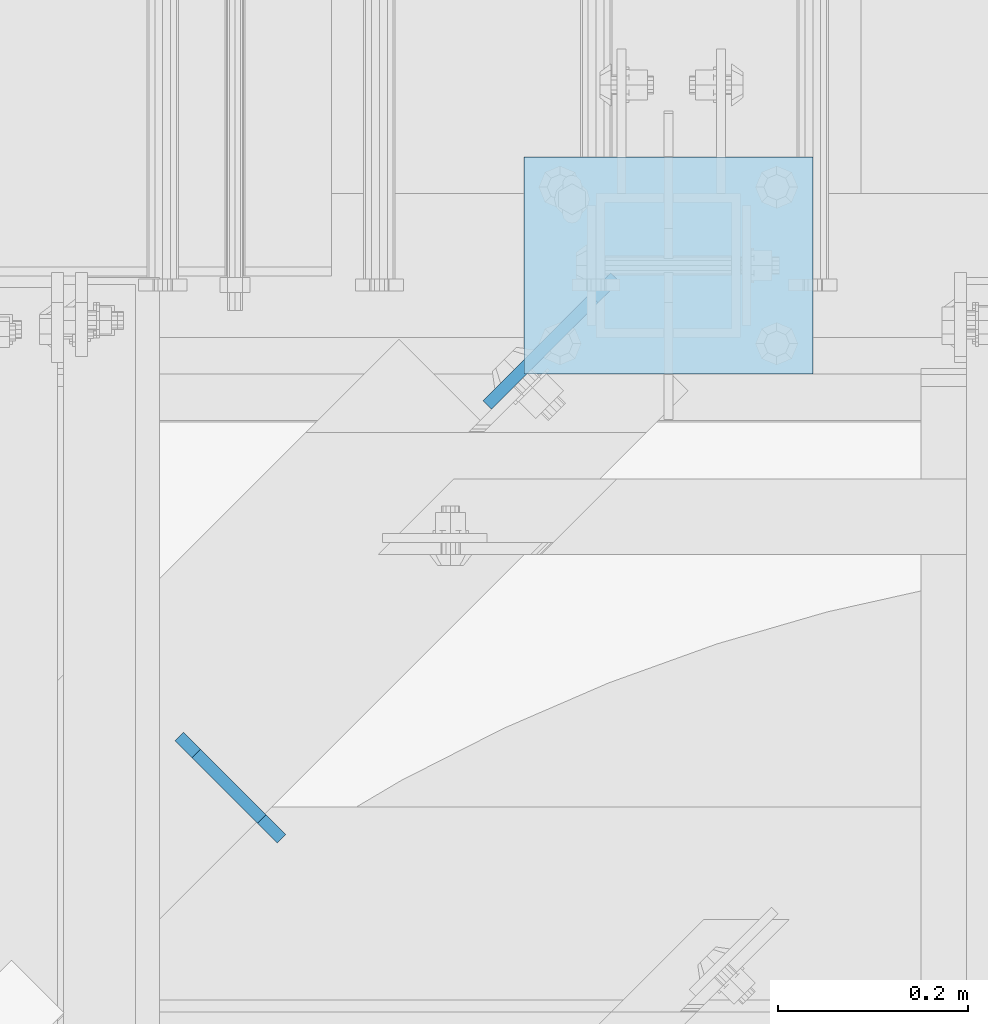
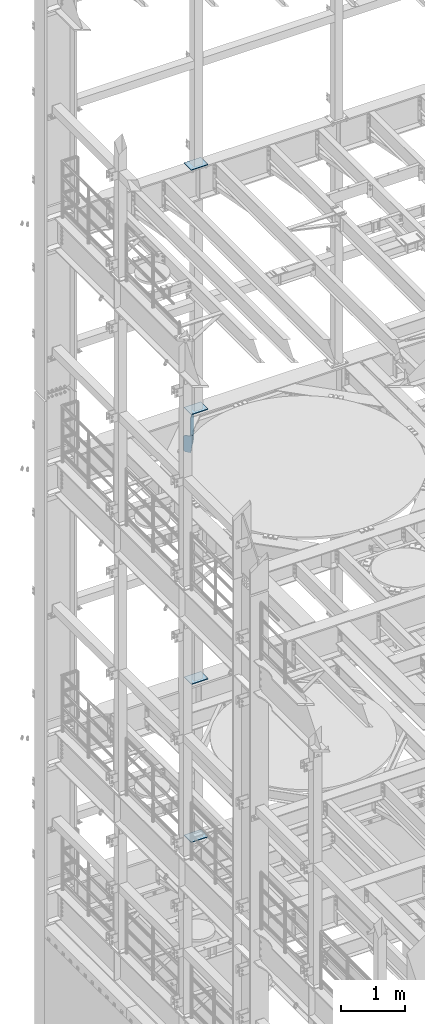
# One storey, part 1777 of 1876: 6 plates, 6 elements without a shape of their own.
"""IFC2X3 building model written with IfcOpenShell, lengths in millimetres."""

from ifc_helpers import new_model, si_unit, frame, origin_with_axes, place, context, subcontext, project, spatial, faceted_brep, material, type_object, element, aggregate, save


model = new_model("IFC2X3")

# Units and contexts
model_context = context("Model", 3, precision=1e-05, world=origin_with_axes())
body_context = subcontext(model_context, "Body", "Model", "MODEL_VIEW")
ifc_project = project(units=[si_unit("LENGTHUNIT", "METRE", prefix="MILLI"), si_unit("AREAUNIT", "SQUARE_METRE"), si_unit("VOLUMEUNIT", "CUBIC_METRE"), si_unit("MASSUNIT", "GRAM", prefix="KILO"), si_unit("TIMEUNIT", "SECOND"), si_unit("PLANEANGLEUNIT", "RADIAN"), si_unit("SOLIDANGLEUNIT", "STERADIAN"), si_unit("THERMODYNAMICTEMPERATUREUNIT", "DEGREE_CELSIUS"), si_unit("LUMINOUSINTENSITYUNIT", "LUMEN")], contexts=[model_context])

# Site, building, storey
site_placement = place(None, origin_with_axes())
site = spatial("IfcSite", under=ifc_project, at=site_placement, CompositionType="ELEMENT")
building_placement = place(site_placement, origin_with_axes())
building = spatial("IfcBuilding", under=site, at=building_placement, Name="Undefined", CompositionType="ELEMENT")
storey_placement = place(building_placement, origin_with_axes())
storey = spatial("IfcBuildingStorey", under=building, at=storey_placement, Name="Undefined", CompositionType="ELEMENT", Elevation=0.0)

# Assembly, plate
assembly_1_placement = place(storey_placement, origin_with_axes())
assembly_1 = element("IfcElementAssembly", 1, at=assembly_1_placement, inside=storey, Name="FRAME", AssemblyPlace="NOTDEFINED", PredefinedType="RIGID_FRAME")
ifc_material = material(Name="STEEL/A36")
plate_type_1 = type_object("IfcPlateType", PredefinedType="NOTDEFINED")
plate_1_placement = place(assembly_1_placement, frame((2692.4, 13601.7, 17989.55), z_axis=(-1.0, 0.0, 0.0), x_axis=(0.0, 1.0, 0.0)))
plate_1 = element("IfcPlate", 2, at=plate_1_placement, type_object=plate_type_1, material=ifc_material, Name="PLATE", context=body_context, shape_type="Brep", body=[
    faceted_brep([(0.0, -6.35000000000036, 0.0), (0.0, -6.35000000000036, 304.799987792969), (0.0, 6.35000000000036, 304.799987792969), (0.0, 6.35000000000036, 0.0), (228.600006103516, -6.34999999999854, 304.799987792969), (228.600006103516, 6.34999999999854, 304.799987792969), (228.600006103516, -6.34999999999854, 0.0), (228.600006103516, 6.34999999999854, 0.0)], [[[0, 1, 2, 3]], [[1, 4, 5, 2]], [[4, 6, 7, 5]], [[6, 0, 3, 7]], [[5, 7, 3, 2]], [[6, 4, 1, 0]]]),
])
aggregate(assembly_1, [plate_1])

assembly_2_placement = place(storey_placement, origin_with_axes())
assembly_2 = element("IfcElementAssembly", 3, at=assembly_2_placement, inside=storey, Name="FRAME", AssemblyPlace="NOTDEFINED", PredefinedType="RIGID_FRAME")
plate_2_placement = place(assembly_2_placement, frame((2692.4, 13601.7, 13315.95), z_axis=(-1.0, 0.0, 0.0), x_axis=(0.0, 1.0, 0.0)))
plate_2 = element("IfcPlate", 4, at=plate_2_placement, type_object=plate_type_1, material=ifc_material, Name="PLATE", context=body_context, shape_type="Brep", body=[
    faceted_brep([(0.0, -6.35000000000036, 0.0), (0.0, -6.35000000000036, 304.799987792969), (0.0, 6.35000000000036, 304.799987792969), (0.0, 6.35000000000036, 0.0), (228.600006103516, -6.34999999999854, 304.799987792969), (228.600006103516, 6.34999999999854, 304.799987792969), (228.600006103516, -6.34999999999854, 0.0), (228.600006103516, 6.34999999999854, 0.0)], [[[0, 1, 2, 3]], [[1, 4, 5, 2]], [[4, 6, 7, 5]], [[6, 0, 3, 7]], [[5, 7, 3, 2]], [[6, 4, 1, 0]]]),
])
aggregate(assembly_2, [plate_2])

assembly_3_placement = place(storey_placement, origin_with_axes())
assembly_3 = element("IfcElementAssembly", 5, at=assembly_3_placement, inside=storey, Name="FRAME", AssemblyPlace="NOTDEFINED", PredefinedType="RIGID_FRAME")
plate_3_placement = place(assembly_3_placement, frame((2692.4, 13601.7, 8159.75), z_axis=(-1.0, 0.0, 0.0), x_axis=(0.0, 1.0, 0.0)))
plate_3 = element("IfcPlate", 6, at=plate_3_placement, type_object=plate_type_1, material=ifc_material, Name="PLATE", context=body_context, shape_type="Brep", body=[
    faceted_brep([(0.0, -6.35000000000036, 0.0), (0.0, -6.35000000000036, 304.799987792969), (0.0, 6.35000000000036, 304.799987792969), (0.0, 6.35000000000036, 0.0), (228.600006103516, -6.34999999999854, 304.799987792969), (228.600006103516, 6.34999999999854, 304.799987792969), (228.600006103516, -6.34999999999854, 0.0), (228.600006103516, 6.34999999999854, 0.0)], [[[0, 1, 2, 3]], [[1, 4, 5, 2]], [[4, 6, 7, 5]], [[6, 0, 3, 7]], [[5, 7, 3, 2]], [[6, 4, 1, 0]]]),
])
aggregate(assembly_3, [plate_3])

assembly_4_placement = place(storey_placement, origin_with_axes())
assembly_4 = element("IfcElementAssembly", 7, at=assembly_4_placement, inside=storey, Name="FRAME", AssemblyPlace="NOTDEFINED", PredefinedType="RIGID_FRAME")
plate_4_placement = place(assembly_4_placement, frame((2692.4, 13601.7, 5137.15), z_axis=(-1.0, 0.0, 0.0), x_axis=(0.0, 1.0, 0.0)))
plate_4 = element("IfcPlate", 8, at=plate_4_placement, type_object=plate_type_1, material=ifc_material, Name="PLATE", context=body_context, shape_type="Brep", body=[
    faceted_brep([(0.0, -6.35000000000036, 0.0), (0.0, -6.35000000000036, 304.799987792969), (0.0, 6.35000000000036, 304.799987792969), (0.0, 6.35000000000036, 0.0), (228.600006103516, -6.34999999999854, 304.799987792969), (228.600006103516, 6.34999999999854, 304.799987792969), (228.600006103516, -6.34999999999854, 0.0), (228.600006103516, 6.34999999999854, 0.0)], [[[0, 1, 2, 3]], [[1, 4, 5, 2]], [[4, 6, 7, 5]], [[6, 0, 3, 7]], [[5, 7, 3, 2]], [[6, 4, 1, 0]]]),
])
aggregate(assembly_4, [plate_4])

assembly_5_placement = place(storey_placement, origin_with_axes())
assembly_5 = element("IfcElementAssembly", 9, at=assembly_5_placement, inside=storey, Name="BEAM", AssemblyPlace="NOTDEFINED", PredefinedType="RIGID_FRAME")
plate_type_2 = type_object("IfcPlateType", PredefinedType="NOTDEFINED")
plate_5_placement = place(assembly_5_placement, frame((2024.101321528, 13219.1376341494, 12974.637), z_axis=(0.707106781186547, -0.707106781186548, 0.0), x_axis=(0.0, 0.0, 1.0)))
plate_5 = element("IfcPlate", 10, at=plate_5_placement, type_object=plate_type_2, material=ifc_material, Name="PLATE", context=body_context, shape_type="Brep", body=[
    faceted_brep([(0.0, -6.35000000000036, 25.4000000000005), (0.0, -6.35000000001855, 120.650001525881), (0.0, 6.34999999998035, 120.650001525879), (0.0, 6.35000000000036, 25.4000000000005), (207.962997436523, -6.35000000002401, 152.399993896486), (207.962997436523, 6.34999999997581, 152.399993896484), (334.963012695312, -6.35000000002401, 152.399993896486), (334.963012695312, 6.34999999997581, 152.399993896484), (334.963012695312, -6.35000000001946, 123.030746459965), (334.963012695312, 6.34999999998035, 123.030746459961), (315.912994384766, -6.35000000001946, 123.030746459965), (315.912994384766, 6.34999999998035, 123.030746459961), (315.912994384766, -6.35000000000491, 25.3999996183684), (315.912994384766, 6.34999999999582, 25.3999996183666), (290.512994766235, -6.34999999999945, -1.4915713109076e-10), (290.512994766235, 6.35000000000036, -1.52795109897852e-10), (25.3999996185303, -6.34999999999991, 0.0), (25.3999996185303, 6.34999999999991, 0.0)], [[[0, 1, 2, 3]], [[1, 4, 5, 2]], [[4, 6, 7, 5]], [[6, 8, 9, 7]], [[8, 10, 11, 9]], [[10, 12, 13, 11]], [[12, 14, 15, 13]], [[14, 16, 17, 15]], [[16, 0, 3, 17]], [[5, 7, 9, 11, 13, 15, 17, 3, 2]], [[16, 14, 12, 10, 8, 6, 4, 1, 0]]]),
])
aggregate(assembly_5, [plate_5])

assembly_6_placement = place(storey_placement, origin_with_axes())
assembly_6 = element("IfcElementAssembly", 11, at=assembly_6_placement, inside=storey, Name="BEAM", AssemblyPlace="NOTDEFINED", PredefinedType="RIGID_FRAME")
plate_type_3 = type_object("IfcPlateType", PredefinedType="NOTDEFINED")
plate_6_placement = place(assembly_6_placement, frame((2483.84035491915, 13703.5723720069, 12709.525), z_axis=(0.0, 0.0, 1.0), x_axis=(-0.707106781186547, -0.707106781186548, 0.0)))
plate_6 = element("IfcPlate", 12, at=plate_6_placement, type_object=plate_type_3, material=ifc_material, Name="PLATE", context=body_context, shape_type="Brep", body=[
    faceted_brep([(0.0, -6.34999999999991, 31.75), (0.0, -6.35000000000036, 541.337524414062), (0.0, 6.35000000000036, 541.337524414062), (0.0, 6.34999999999991, 31.75), (31.75, -6.35000000000036, 573.087524414062), (31.75, 6.35000000000036, 573.087524414062), (190.500000000033, -6.35000000000036, 573.087524414062), (190.500000000034, 6.35000000000036, 573.087524414062), (190.500000000031, -6.35000000000036, 0.0), (190.500000000034, 6.35000000000036, 0.0), (31.75, -6.34999999999991, 0.0), (31.75, 6.34999999999991, 0.0)], [[[0, 1, 2, 3]], [[1, 4, 5, 2]], [[4, 6, 7, 5]], [[6, 8, 9, 7]], [[8, 10, 11, 9]], [[10, 0, 3, 11]], [[5, 7, 9, 11, 3, 2]], [[10, 8, 6, 4, 1, 0]]]),
])
aggregate(assembly_6, [plate_6])

save(model, "model.ifc")
